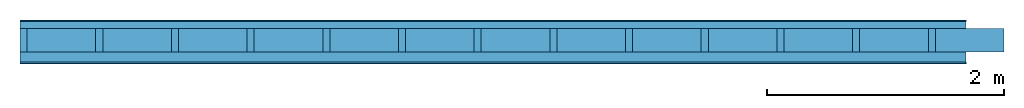
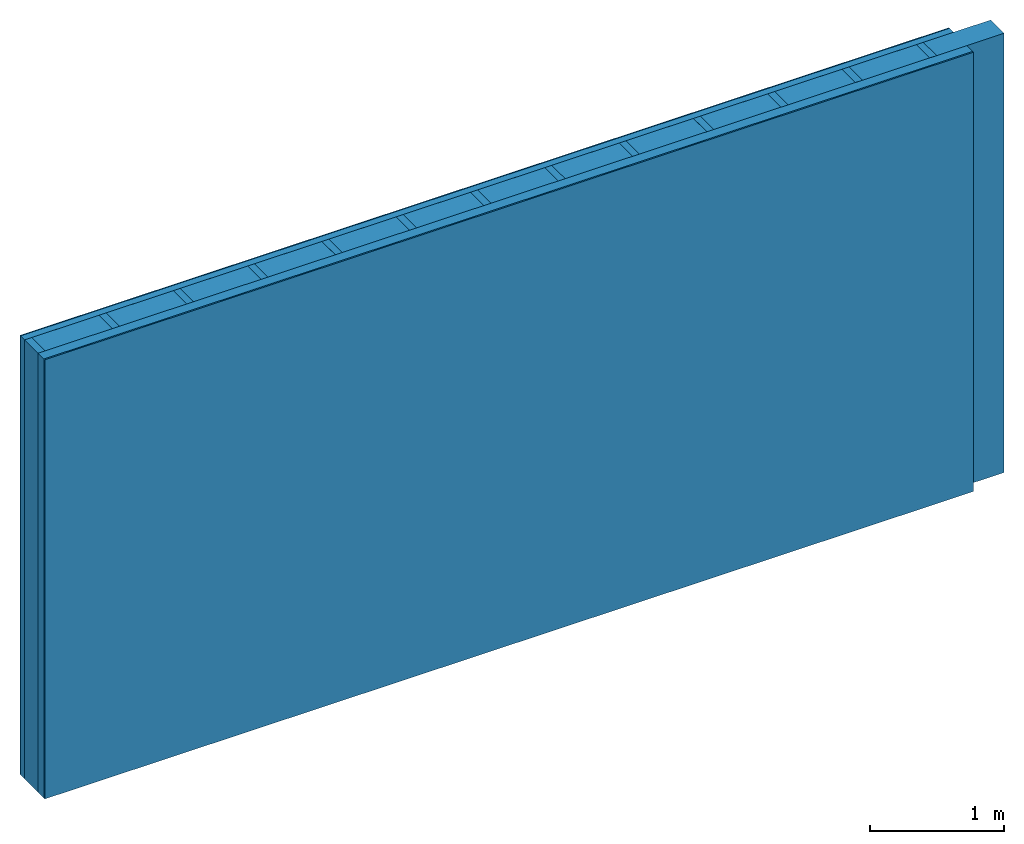
# One storey: 4 plates, 2 members, 1 element without a shape of its own.
"""IFC4 building model written with IfcOpenShell, lengths in metres."""

from ifc_helpers import new_model, si_unit, derived_unit, direction, frame, frame_2d, origin, origin_with_axes, place, context, project, spatial, rectangle, extrude, material, layer, layer_set, type_object, element, aggregate, save


model = new_model("IFC4")

# Units and contexts
plan_context = context("Plan", 3, precision=1e-05, world=origin(), true_north=direction((0.0, 1.0)))
model_context = context("Model", 3, precision=1e-05, world=origin(), true_north=direction((0.0, 1.0)))
ifc_project = project(units=[si_unit("LENGTHUNIT", "METRE"), derived_unit("SOUNDPRESSUREUNIT", [(si_unit("PRESSUREUNIT", "PASCAL", prefix="MICRO"), 0)]), si_unit("ENERGYUNIT", "JOULE", prefix="MEGA"), si_unit("MASSUNIT", "GRAM", prefix="KILO"), derived_unit("THERMALTRANSMITTANCEUNIT", [(si_unit("POWERUNIT", "WATT"), 1), (si_unit("AREAUNIT", "SQUARE_METRE"), -1), (si_unit("THERMODYNAMICTEMPERATUREUNIT", "KELVIN"), -1)]), derived_unit("AREADENSITYUNIT", [(si_unit("MASSUNIT", "GRAM", prefix="KILO"), 1), (si_unit("AREAUNIT", "SQUARE_METRE"), -1)]), derived_unit("USERDEFINED", [(si_unit("ENERGYUNIT", "JOULE", prefix="MEGA"), 1), (si_unit("AREAUNIT", "SQUARE_METRE"), -1)])], contexts=[plan_context, model_context])

# Site, building, storey
site = spatial("IfcSite", under=ifc_project)
building_placement = place(None, origin())
building = spatial("IfcBuilding", under=site, at=building_placement)
storey_placement = place(building_placement, origin())
storey = spatial("IfcBuildingStorey", under=building, at=storey_placement)

# Wall, members, plates
ifc_material_1 = material(Category="04.011")
ifc_layer_1 = layer(ifc_material_1, 0.01, Name="Surface 1")
ifc_material_2 = material(Category="10.009")
ifc_layer_2 = layer(ifc_material_2, 0.06, Name="outside 1st layer")
ifc_material_3 = material(Name="of the art")
ifc_layer_3 = layer(ifc_material_3, 0.0, Name="Bond")
ifc_layer_4 = layer(None, 0.2, Name="Support")
ifc_layer_5 = layer(ifc_material_3, 0.0, Name="Bond")
ifc_material_4 = material(Name="Solid timber panel")
ifc_layer_6 = layer(ifc_material_4, 0.087, Name="1st layer")
ifc_material_5 = material(Name="Plasterboard type A", Category="03.008")
ifc_layer_7 = layer(ifc_material_5, 0.0125, Name="Covering 1st layer")
ifc_material_6 = material(Name="joints", Category="04.017")
ifc_layer_8 = layer(ifc_material_6, 0.0, Name="Surface")
ifc_layer_set = layer_set([ifc_layer_1, ifc_layer_2, ifc_layer_3, ifc_layer_4, ifc_layer_5, ifc_layer_6, ifc_layer_7, ifc_layer_8])
wall_type = type_object("IfcWallType", Name="D0981", PredefinedType="NOTDEFINED", material=ifc_layer_set)
wall_placement = place(None, frame((0.0, 0.0, 0.0), z_axis=(0.0, -1.0, 0.0), x_axis=(1.0, 0.0, 0.0)))
wall = element("IfcWall", 1, at=wall_placement, inside=storey, type_object=wall_type, material=ifc_layer_set, Name="Wall #1")
ifc_material_7 = material()
member_1_placement = place(wall_placement, origin())
member_1 = element("IfcMember", 2, at=member_1_placement, material=ifc_material_7, Name="Support", context=plan_context, shape_type="SweptSolid", body=[
    extrude(rectangle(XDim=0.06, YDim=0.2, at=frame_2d((0.03, 0.1), x_axis=(1.0, 0.0))), frame((0.0, 4.0, 0.07), z_axis=(0.0, -1.0, 0.0), x_axis=(1.0, 0.0, 0.0)), (0.0, 0.0, 1.0), 4.0),
    extrude(rectangle(XDim=0.06, YDim=0.2, at=frame_2d((0.03, 0.1), x_axis=(1.0, 0.0))), frame((0.64, 4.0, 0.07), z_axis=(0.0, -1.0, 0.0), x_axis=(1.0, 0.0, 0.0)), (0.0, 0.0, 1.0), 4.0),
    extrude(rectangle(XDim=0.06, YDim=0.2, at=frame_2d((0.03, 0.1), x_axis=(1.0, 0.0))), frame((1.28, 4.0, 0.07), z_axis=(0.0, -1.0, 0.0), x_axis=(1.0, 0.0, 0.0)), (0.0, 0.0, 1.0), 4.0),
    extrude(rectangle(XDim=0.06, YDim=0.2, at=frame_2d((0.03, 0.1), x_axis=(1.0, 0.0))), frame((1.92, 4.0, 0.07), z_axis=(0.0, -1.0, 0.0), x_axis=(1.0, 0.0, 0.0)), (0.0, 0.0, 1.0), 4.0),
    extrude(rectangle(XDim=0.06, YDim=0.2, at=frame_2d((0.03, 0.1), x_axis=(1.0, 0.0))), frame((2.56, 4.0, 0.07), z_axis=(0.0, -1.0, 0.0), x_axis=(1.0, 0.0, 0.0)), (0.0, 0.0, 1.0), 4.0),
    extrude(rectangle(XDim=0.06, YDim=0.2, at=frame_2d((0.03, 0.1), x_axis=(1.0, 0.0))), frame((3.2, 4.0, 0.07), z_axis=(0.0, -1.0, 0.0), x_axis=(1.0, 0.0, 0.0)), (0.0, 0.0, 1.0), 4.0),
    extrude(rectangle(XDim=0.06, YDim=0.2, at=frame_2d((0.03, 0.1), x_axis=(1.0, 0.0))), frame((3.84, 4.0, 0.07), z_axis=(0.0, -1.0, 0.0), x_axis=(1.0, 0.0, 0.0)), (0.0, 0.0, 1.0), 4.0),
    extrude(rectangle(XDim=0.06, YDim=0.2, at=frame_2d((0.03, 0.1), x_axis=(1.0, 0.0))), frame((4.48, 4.0, 0.07), z_axis=(0.0, -1.0, 0.0), x_axis=(1.0, 0.0, 0.0)), (0.0, 0.0, 1.0), 4.0),
    extrude(rectangle(XDim=0.06, YDim=0.2, at=frame_2d((0.03, 0.1), x_axis=(1.0, 0.0))), frame((5.12, 4.0, 0.07), z_axis=(0.0, -1.0, 0.0), x_axis=(1.0, 0.0, 0.0)), (0.0, 0.0, 1.0), 4.0),
    extrude(rectangle(XDim=0.06, YDim=0.2, at=frame_2d((0.03, 0.1), x_axis=(1.0, 0.0))), frame((5.76, 4.0, 0.07), z_axis=(0.0, -1.0, 0.0), x_axis=(1.0, 0.0, 0.0)), (0.0, 0.0, 1.0), 4.0),
    extrude(rectangle(XDim=0.06, YDim=0.2, at=frame_2d((0.03, 0.1), x_axis=(1.0, 0.0))), frame((6.4, 4.0, 0.07), z_axis=(0.0, -1.0, 0.0), x_axis=(1.0, 0.0, 0.0)), (0.0, 0.0, 1.0), 4.0),
    extrude(rectangle(XDim=0.06, YDim=0.2, at=frame_2d((0.03, 0.1), x_axis=(1.0, 0.0))), frame((7.04, 4.0, 0.07), z_axis=(0.0, -1.0, 0.0), x_axis=(1.0, 0.0, 0.0)), (0.0, 0.0, 1.0), 4.0),
    extrude(rectangle(XDim=0.06, YDim=0.2, at=frame_2d((0.03, 0.1), x_axis=(1.0, 0.0))), frame((7.68, 4.0, 0.07), z_axis=(0.0, -1.0, 0.0), x_axis=(1.0, 0.0, 0.0)), (0.0, 0.0, 1.0), 4.0),
])
ifc_material_8 = material()
member_2_placement = place(wall_placement, origin())
member_2 = element("IfcMember", 3, at=member_2_placement, material=ifc_material_8, Name="Cavity", context=plan_context, shape_type="SweptSolid", body=[
    extrude(rectangle(XDim=0.58, YDim=0.2, at=frame_2d((0.29, 0.1), x_axis=(1.0, 0.0))), frame((0.06, 4.0, 0.07), z_axis=(0.0, -1.0, 0.0), x_axis=(1.0, 0.0, 0.0)), (0.0, 0.0, 1.0), 4.0),
    extrude(rectangle(XDim=0.58, YDim=0.2, at=frame_2d((0.29, 0.1), x_axis=(1.0, 0.0))), frame((0.7, 4.0, 0.07), z_axis=(0.0, -1.0, 0.0), x_axis=(1.0, 0.0, 0.0)), (0.0, 0.0, 1.0), 4.0),
    extrude(rectangle(XDim=0.58, YDim=0.2, at=frame_2d((0.29, 0.1), x_axis=(1.0, 0.0))), frame((1.34, 4.0, 0.07), z_axis=(0.0, -1.0, 0.0), x_axis=(1.0, 0.0, 0.0)), (0.0, 0.0, 1.0), 4.0),
    extrude(rectangle(XDim=0.58, YDim=0.2, at=frame_2d((0.29, 0.1), x_axis=(1.0, 0.0))), frame((1.98, 4.0, 0.07), z_axis=(0.0, -1.0, 0.0), x_axis=(1.0, 0.0, 0.0)), (0.0, 0.0, 1.0), 4.0),
    extrude(rectangle(XDim=0.58, YDim=0.2, at=frame_2d((0.29, 0.1), x_axis=(1.0, 0.0))), frame((2.62, 4.0, 0.07), z_axis=(0.0, -1.0, 0.0), x_axis=(1.0, 0.0, 0.0)), (0.0, 0.0, 1.0), 4.0),
    extrude(rectangle(XDim=0.58, YDim=0.2, at=frame_2d((0.29, 0.1), x_axis=(1.0, 0.0))), frame((3.26, 4.0, 0.07), z_axis=(0.0, -1.0, 0.0), x_axis=(1.0, 0.0, 0.0)), (0.0, 0.0, 1.0), 4.0),
    extrude(rectangle(XDim=0.58, YDim=0.2, at=frame_2d((0.29, 0.1), x_axis=(1.0, 0.0))), frame((3.9, 4.0, 0.07), z_axis=(0.0, -1.0, 0.0), x_axis=(1.0, 0.0, 0.0)), (0.0, 0.0, 1.0), 4.0),
    extrude(rectangle(XDim=0.58, YDim=0.2, at=frame_2d((0.29, 0.1), x_axis=(1.0, 0.0))), frame((4.54, 4.0, 0.07), z_axis=(0.0, -1.0, 0.0), x_axis=(1.0, 0.0, 0.0)), (0.0, 0.0, 1.0), 4.0),
    extrude(rectangle(XDim=0.58, YDim=0.2, at=frame_2d((0.29, 0.1), x_axis=(1.0, 0.0))), frame((5.18, 4.0, 0.07), z_axis=(0.0, -1.0, 0.0), x_axis=(1.0, 0.0, 0.0)), (0.0, 0.0, 1.0), 4.0),
    extrude(rectangle(XDim=0.58, YDim=0.2, at=frame_2d((0.29, 0.1), x_axis=(1.0, 0.0))), frame((5.82, 4.0, 0.07), z_axis=(0.0, -1.0, 0.0), x_axis=(1.0, 0.0, 0.0)), (0.0, 0.0, 1.0), 4.0),
    extrude(rectangle(XDim=0.58, YDim=0.2, at=frame_2d((0.29, 0.1), x_axis=(1.0, 0.0))), frame((6.46, 4.0, 0.07), z_axis=(0.0, -1.0, 0.0), x_axis=(1.0, 0.0, 0.0)), (0.0, 0.0, 1.0), 4.0),
    extrude(rectangle(XDim=0.58, YDim=0.2, at=frame_2d((0.29, 0.1), x_axis=(1.0, 0.0))), frame((7.1, 4.0, 0.07), z_axis=(0.0, -1.0, 0.0), x_axis=(1.0, 0.0, 0.0)), (0.0, 0.0, 1.0), 4.0),
    extrude(rectangle(XDim=0.58, YDim=0.2, at=frame_2d((0.29, 0.1), x_axis=(1.0, 0.0))), frame((7.74, 4.0, 0.07), z_axis=(0.0, -1.0, 0.0), x_axis=(1.0, 0.0, 0.0)), (0.0, 0.0, 1.0), 4.0),
])
plate_1_placement = place(wall_placement, origin())
plate_1 = element("IfcPlate", 4, at=plate_1_placement, material=ifc_material_1, Name="Surface 1", context=plan_context, shape_type="SweptSolid", body=[
    extrude(rectangle(XDim=8.0, YDim=4.0, at=frame_2d((4.0, 2.0), x_axis=(1.0, 0.0))), origin_with_axes(), (0.0, 0.0, 1.0), 0.01),
])
plate_2_placement = place(wall_placement, origin())
plate_2 = element("IfcPlate", 5, at=plate_2_placement, material=ifc_material_2, Name="outside 1st layer", context=plan_context, shape_type="SweptSolid", body=[
    extrude(rectangle(XDim=8.0, YDim=4.0, at=frame_2d((4.0, 2.0), x_axis=(1.0, 0.0))), frame((0.0, 0.0, 0.01), z_axis=(0.0, 0.0, 1.0), x_axis=(1.0, 0.0, 0.0)), (0.0, 0.0, 1.0), 0.06),
])
plate_3_placement = place(wall_placement, origin())
plate_3 = element("IfcPlate", 6, at=plate_3_placement, material=ifc_material_4, Name="1st layer", context=plan_context, shape_type="SweptSolid", body=[
    extrude(rectangle(XDim=8.0, YDim=4.0, at=frame_2d((4.0, 2.0), x_axis=(1.0, 0.0))), frame((0.0, 0.0, 0.27), z_axis=(0.0, 0.0, 1.0), x_axis=(1.0, 0.0, 0.0)), (0.0, 0.0, 1.0), 0.087),
])
plate_4_placement = place(wall_placement, origin())
plate_4 = element("IfcPlate", 7, at=plate_4_placement, material=ifc_material_5, Name="Covering 1st layer", context=plan_context, shape_type="SweptSolid", body=[
    extrude(rectangle(XDim=8.0, YDim=4.0, at=frame_2d((4.0, 2.0), x_axis=(1.0, 0.0))), frame((0.0, 0.0, 0.357), z_axis=(0.0, 0.0, 1.0), x_axis=(1.0, 0.0, 0.0)), (0.0, 0.0, 1.0), 0.0125),
])
aggregate(wall, [plate_1, plate_2, member_1, member_2, plate_3, plate_4])

save(model, "model.ifc")
